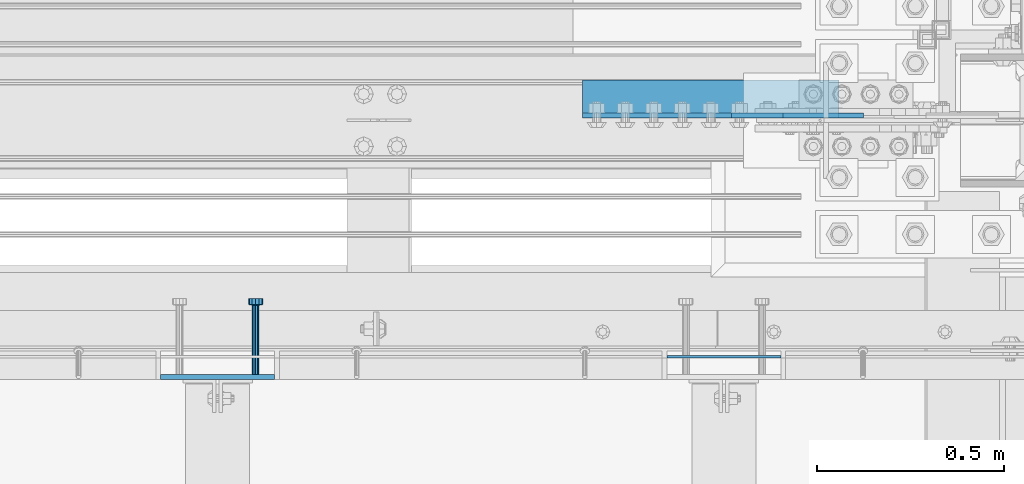
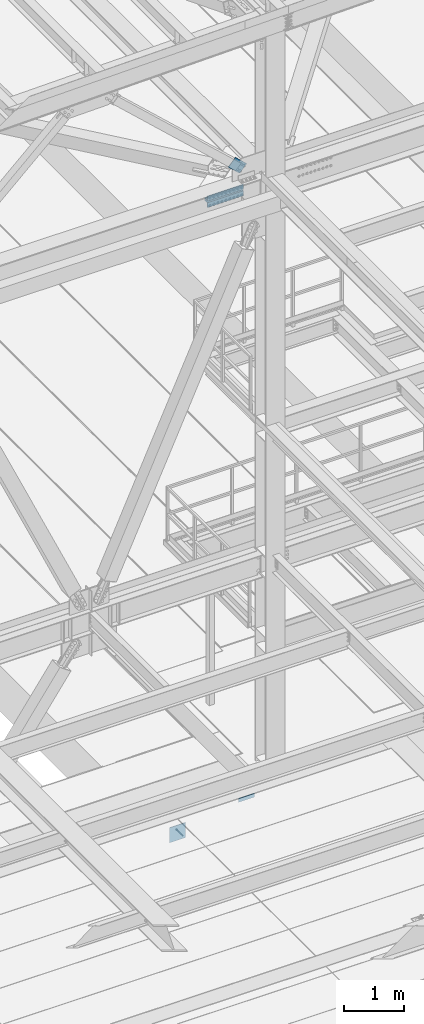
# One storey, part 2101 of 3843: 5 beams, 1 member, 4 elements without a shape of their own.
"""IFC2X3 building model written with IfcOpenShell, lengths in millimetres."""

from ifc_helpers import new_model, si_unit, frame, origin_with_axes, place, context, subcontext, project, spatial, faceted_brep, material, type_object, element, aggregate, save


model = new_model("IFC2X3")

# Units and contexts
model_context = context("Model", 3, precision=1e-05, world=origin_with_axes())
body_context = subcontext(model_context, "Body", "Model", "MODEL_VIEW")
ifc_project = project(units=[si_unit("LENGTHUNIT", "METRE", prefix="MILLI"), si_unit("AREAUNIT", "SQUARE_METRE"), si_unit("VOLUMEUNIT", "CUBIC_METRE"), si_unit("MASSUNIT", "GRAM", prefix="KILO"), si_unit("TIMEUNIT", "SECOND"), si_unit("PLANEANGLEUNIT", "RADIAN"), si_unit("SOLIDANGLEUNIT", "STERADIAN"), si_unit("THERMODYNAMICTEMPERATUREUNIT", "DEGREE_CELSIUS"), si_unit("LUMINOUSINTENSITYUNIT", "LUMEN")], contexts=[model_context])

# Site, building, storey
site_placement = place(None, origin_with_axes())
site = spatial("IfcSite", under=ifc_project, at=site_placement, CompositionType="ELEMENT")
building_placement = place(site_placement, origin_with_axes())
building = spatial("IfcBuilding", under=site, at=building_placement, Name="Undefined", CompositionType="ELEMENT")
storey_placement = place(building_placement, origin_with_axes())
storey = spatial("IfcBuildingStorey", under=building, at=storey_placement, Name="Undefined", CompositionType="ELEMENT", Elevation=0.0)

# Assembly, beam
assembly_1_placement = place(storey_placement, origin_with_axes())
assembly_1 = element("IfcElementAssembly", 1, at=assembly_1_placement, inside=storey, Name="EMBED PLATE", AssemblyPlace="NOTDEFINED", PredefinedType="RIGID_FRAME")
ifc_material_1 = material(Name="STEEL/A36")
beam_type_1 = type_object("IfcBeamType", PredefinedType="NOTDEFINED")
beam_1_placement = place(assembly_1_placement, frame((48028.225, 24984.0749969483, 30441.9), z_axis=(0.0, 0.0, 1.0), x_axis=(1.0, 0.0, 0.0)))
beam_1 = element("IfcBeam", 2, at=beam_1_placement, type_object=beam_type_1, material=ifc_material_1, Name="PLATE", context=body_context, shape_type="Brep", body=[
    faceted_brep([(0.0, 3.17500000000291, -38.0999999999985), (0.0, 3.17500000000291, 38.0999999999985), (304.800000000003, 3.17499999999927, 38.0999999999985), (304.800000000003, 3.17499999999927, -38.0999999999985), (0.0, -3.17500000000291, 38.0999999999985), (304.800000000003, -3.17499999999927, 38.0999999999985), (0.0, -3.17500000000291, -38.0999999999985), (304.800000000003, -3.17499999999927, -38.0999999999985)], [[[0, 1, 2, 3]], [[1, 4, 5, 2]], [[4, 6, 7, 5]], [[6, 0, 3, 7]], [[5, 7, 3, 2]], [[6, 4, 1, 0]]]),
])
aggregate(assembly_1, [beam_1])

assembly_2_placement = place(storey_placement, origin_with_axes())
assembly_2 = element("IfcElementAssembly", 3, at=assembly_2_placement, inside=storey, Name="EMBED PLATE", AssemblyPlace="NOTDEFINED", PredefinedType="RIGID_FRAME")
beam_type_2 = type_object("IfcBeamType", PredefinedType="NOTDEFINED")
beam_2_placement = place(assembly_2_placement, frame((46828.075, 24930.0999969483, 30397.45), z_axis=(1.0, 0.0, 0.0), x_axis=(0.0, 0.0, -1.0)))
beam_2 = element("IfcBeam", 4, at=beam_2_placement, type_object=beam_type_2, material=ifc_material_1, Name="EMBED PLATE", context=body_context, shape_type="Brep", body=[
    faceted_brep([(-1.0550138540566e-10, 6.34999999999854, -152.400000000664), (1.0550138540566e-10, 6.34999999999854, 152.400000000656), (304.799999999999, 6.34999999999854, 152.400000000001), (304.799999999999, 6.34999999999854, -152.400000000001), (1.0550138540566e-10, -6.34999999999854, 152.400000000656), (304.799999999999, -6.34999999999854, 152.400000000001), (-1.0550138540566e-10, -6.34999999999854, -152.400000000664), (304.799999999999, -6.34999999999854, -152.400000000001)], [[[0, 1, 2, 3]], [[1, 4, 5, 2]], [[4, 6, 7, 5]], [[6, 0, 3, 7]], [[5, 7, 3, 2]], [[6, 4, 1, 0]]]),
])

# Assembly, beams
assembly_3_placement = place(storey_placement, origin_with_axes())
assembly_3 = element("IfcElementAssembly", 5, at=assembly_3_placement, inside=storey, Name="PLATE", AssemblyPlace="NOTDEFINED", PredefinedType="RIGID_FRAME")
ifc_material_2 = material(Name="STEEL/A572-50")
beam_type_3 = type_object("IfcBeamType", Name="L4X4X1/2", PredefinedType="NOTDEFINED")
beam_3_placement = place(assembly_3_placement, frame((47802.8, 25673.0499999491, 42297.35), z_axis=(0.0, 1.0, 0.0), x_axis=(1.0, 0.0, 0.0)))
beam_3 = element("IfcBeam", 6, at=beam_3_placement, type_object=beam_type_3, material=ifc_material_2, Name="ANGLE", ObjectType="L4X4X1/2", context=body_context, shape_type="Brep", body=[
    faceted_brep([(0.0, 50.8000000000029, -50.8000000000029), (0.0, 50.8000000000029, 50.8000000000029), (685.800000000003, 50.8000000000029, 50.8000000000029), (685.800000000003, 50.8000000000029, -50.8000000000029), (0.0, 38.0999999999985, 50.8000000000029), (685.800000000003, 38.0999999999985, 50.8000000000029), (0.0, 38.0999999999985, -38.0999999999985), (685.800000000003, 38.0999999999985, -38.1000000000058), (0.0, -50.8000000000029, -38.1000000000058), (685.800000000003, -50.8000000000029, -38.1000000000058), (0.0, -50.8000000000029, -50.8000000000029), (685.800000000003, -50.8000000000029, -50.8000000000029)], [[[0, 1, 2, 3]], [[1, 4, 5, 2]], [[4, 6, 7, 5]], [[6, 8, 9, 7]], [[8, 10, 11, 9]], [[10, 0, 3, 11]], [[5, 7, 9, 11, 3, 2]], [[10, 8, 6, 4, 1, 0]]]),
])
beam_4_placement = place(assembly_3_placement, frame((48488.6, 25673.0499999491, 42167.175), z_axis=(0.0, 1.0, 0.0), x_axis=(-1.0, 0.0, 0.0)))
beam_4 = element("IfcBeam", 7, at=beam_4_placement, type_object=beam_type_3, material=ifc_material_2, Name="ANGLE", ObjectType="L4X4X1/2", context=body_context, shape_type="Brep", body=[
    faceted_brep([(0.0, 50.8000000000029, -50.8000000000029), (0.0, 50.8000000000029, 50.8000000000029), (685.800000000003, 50.8000000000029, 50.8000000000029), (685.800000000003, 50.8000000000029, -50.8000000000029), (0.0, 38.0999999999985, 50.8000000000029), (685.800000000003, 38.0999999999985, 50.8000000000029), (0.0, 38.0999999999985, -38.0999999999985), (685.800000000003, 38.0999999999985, -38.1000000000058), (0.0, -50.8000000000029, -38.1000000000058), (685.800000000003, -50.8000000000029, -38.1000000000058), (0.0, -50.8000000000029, -50.8000000000029), (685.800000000003, -50.8000000000029, -50.8000000000029)], [[[0, 1, 2, 3]], [[1, 4, 5, 2]], [[4, 6, 7, 5]], [[6, 8, 9, 7]], [[8, 10, 11, 9]], [[10, 0, 3, 11]], [[5, 7, 9, 11, 3, 2]], [[10, 8, 6, 4, 1, 0]]]),
])
aggregate(assembly_3, [beam_3, beam_4])

# Assembly, member
assembly_4_placement = place(storey_placement, origin_with_axes())
assembly_4 = element("IfcElementAssembly", 8, at=assembly_4_placement, inside=storey, AssemblyPlace="NOTDEFINED", PredefinedType="RIGID_FRAME")
member_type = type_object("IfcMemberType", PredefinedType="NOTDEFINED")
member_placement = place(assembly_4_placement, frame((48484.4078975788, 25628.6000000156, 42670.4339661436), z_axis=(-0.678515287903948, 0.0, -0.734586280896004), x_axis=(-0.734586280896008, 0.0, 0.678515287903943)))
member = element("IfcMember", 9, at=member_placement, type_object=member_type, material=ifc_material_2, Name="PLATE", context=body_context, shape_type="Brep", body=[
    faceted_brep([(1.74622982740402e-10, 6.35000000000582, -101.600000000195), (-1.67347025126219e-10, 6.35000000000582, 101.600000000151), (292.1000000028, 6.35000000000582, 101.600000000661), (292.100000003156, 6.35000000000582, -101.599999999686), (-1.67347025126219e-10, -6.35000000000582, 101.600000000151), (292.1000000028, -6.35000000000582, 101.600000000661), (1.74622982740402e-10, -6.35000000000582, -101.600000000195), (292.100000003156, -6.35000000000582, -101.599999999686)], [[[0, 1, 2, 3]], [[1, 4, 5, 2]], [[4, 6, 7, 5]], [[6, 0, 3, 7]], [[5, 7, 3, 2]], [[6, 4, 1, 0]]]),
])
aggregate(assembly_4, [member])

# Beam
ifc_material_3 = material(Name="STEEL/A108")
beam_type_4 = type_object("IfcBeamType", PredefinedType="NOTDEFINED")
beam_5_placement = place(assembly_2_placement, frame((46929.675, 24936.4499969483, 30143.45), z_axis=(-1.0, 0.0, 0.0), x_axis=(0.0, 1.0, 0.0)))
beam_5 = element("IfcBeam", 10, at=beam_5_placement, type_object=beam_type_4, material=ifc_material_3, Name="HEADED STUD ANCHOR", context=body_context, shape_type="Brep", body=[
    faceted_brep([(0.0, -9.52000045776367, 0.0), (0.0, -8.25, -4.76000022888184), (184.912000000004, -8.25, -4.76000022888184), (184.912000000004, -9.52000045776367, 0.0), (0.0, -4.76000022888184, -8.25), (184.912000000004, -4.76000022888184, -8.25), (0.0, 0.0, -9.52000045776367), (184.912000000004, 0.0, -9.52000045776367), (0.0, 4.76000022888184, -8.25), (184.912000000004, 4.76000022888184, -8.25), (0.0, 8.25, -4.76000022888184), (184.912000000004, 8.25, -4.76000022888184), (0.0, 9.52000045776367, 0.0), (184.912000000004, 9.52000045776367, 0.0), (0.0, 8.25, 4.76000022888184), (184.912000000004, 8.25, 4.76000022888184), (0.0, 4.76000022888184, 8.25), (184.912000000004, 4.76000022888184, 8.25), (0.0, 0.0, 9.52000045776367), (184.912000000004, 0.0, 9.52000045776367), (0.0, -4.76000022888184, 8.25), (184.912000000004, -4.76000022888184, 8.25), (0.0, -8.25, 4.76000022888184), (184.912000000004, -8.25, 4.76000022888184), (186.944000000003, -16.5, -9.52000045776367), (186.944000000003, -19.0499992370605, 0.0), (186.944000000003, -9.52000045776367, -16.5), (186.944000000003, 0.0, -19.0499992370605), (186.944000000003, 9.52000045776367, -16.5), (186.944000000003, 16.5, -9.52000045776367), (186.944000000003, 19.0499992370605, 0.0), (186.944000000003, 16.5, 9.52000045776367), (186.944000000003, 9.52000045776367, 16.5), (186.944000000003, 0.0, 19.0499992370605), (186.944000000003, -9.52000045776367, 16.5), (186.944000000003, -16.5, 9.52000045776367), (203.199999999997, -16.5, -9.52000045776367), (203.199999999997, -19.0499992370605, 0.0), (203.199999999997, -9.52000045776367, -16.5), (203.199999999997, 0.0, -19.0499992370605), (203.199999999997, 9.52000045776367, -16.5), (203.199999999997, 16.5, -9.52000045776367), (203.199999999997, 19.0499992370605, 0.0), (203.199999999997, 16.5, 9.52000045776367), (203.199999999997, 9.52000045776367, 16.5), (203.199999999997, 0.0, 19.0499992370605), (203.199999999997, -9.52000045776367, 16.5), (203.199999999997, -16.5, 9.52000045776367)], [[[0, 1, 2, 3]], [[1, 4, 5, 2]], [[4, 6, 7, 5]], [[6, 8, 9, 7]], [[8, 10, 11, 9]], [[10, 12, 13, 11]], [[12, 14, 15, 13]], [[14, 16, 17, 15]], [[16, 18, 19, 17]], [[18, 20, 21, 19]], [[20, 22, 23, 21]], [[22, 0, 3, 23]], [[22, 20, 18, 16, 14, 12, 10, 8, 6, 4, 1, 0]], [[3, 2, 24, 25]], [[2, 5, 26, 24]], [[5, 7, 27, 26]], [[7, 9, 28, 27]], [[9, 11, 29, 28]], [[11, 13, 30, 29]], [[13, 15, 31, 30]], [[15, 17, 32, 31]], [[17, 19, 33, 32]], [[19, 21, 34, 33]], [[21, 23, 35, 34]], [[23, 3, 25, 35]], [[25, 24, 36, 37]], [[24, 26, 38, 36]], [[26, 27, 39, 38]], [[27, 28, 40, 39]], [[28, 29, 41, 40]], [[29, 30, 42, 41]], [[30, 31, 43, 42]], [[31, 32, 44, 43]], [[32, 33, 45, 44]], [[33, 34, 46, 45]], [[34, 35, 47, 46]], [[35, 25, 37, 47]], [[38, 39, 40, 41, 42, 43, 44, 45, 46, 47, 37, 36]]]),
])

aggregate(assembly_2, [beam_5, beam_2])

save(model, "model.ifc")
